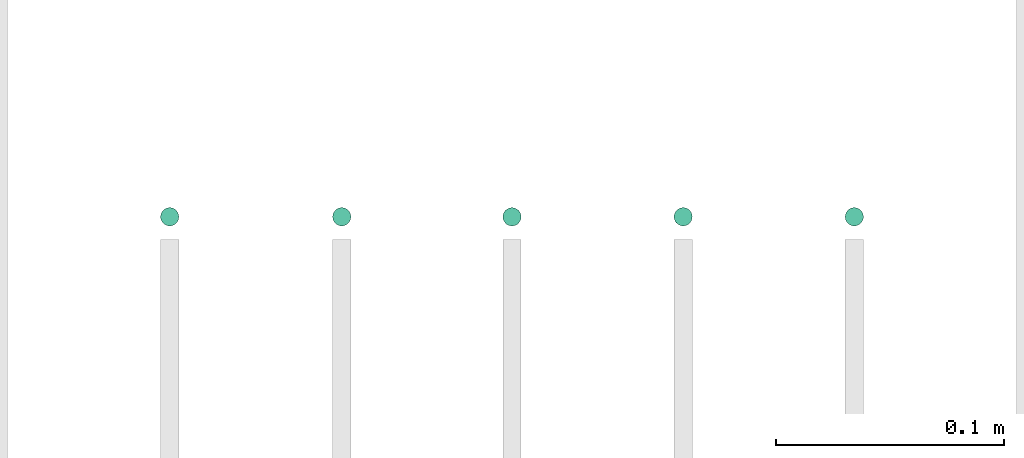
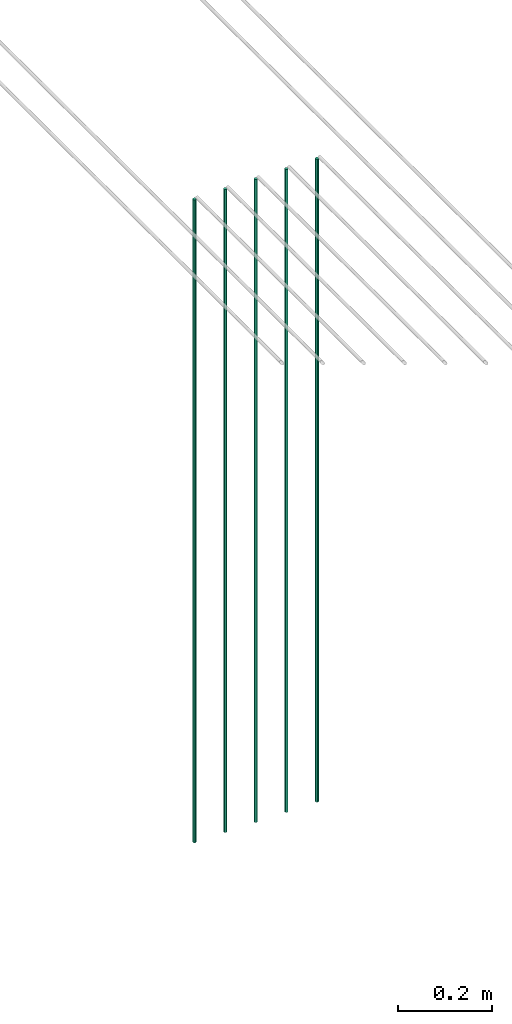
# One storey, part 12 of 89: 5 flow segments.
"""IFC2X3 building model written with IfcOpenShell, lengths in millimetres."""

from ifc_helpers import new_model, entity, si_unit, converted_unit, derived_unit, direction, frame, frame_2d, origin, origin_2d_with_axis, place, context, subcontext, project, spatial, circle, extrude, type_object, element, save


model = new_model("IFC2X3")

# Units and contexts
model_context = context("Model", 3, precision=0.01, world=origin(), true_north=direction((6.12303176911189e-17, 1.0)))
body_context = subcontext(model_context, "Body", "Model", "MODEL_VIEW")
ifc_project = project(units=[si_unit("LENGTHUNIT", "METRE", prefix="MILLI"), si_unit("AREAUNIT", "SQUARE_METRE"), si_unit("VOLUMEUNIT", "CUBIC_METRE"), converted_unit("PLANEANGLEUNIT", "DEGREE", entity("IfcRatioMeasure", 0.0174532925199433), si_unit("PLANEANGLEUNIT", "RADIAN"), dimensions=[0, 0, 0, 0, 0, 0, 0]), si_unit("MASSUNIT", "GRAM", prefix="KILO"), derived_unit("MASSDENSITYUNIT", [(si_unit("MASSUNIT", "GRAM", prefix="KILO"), 1), (si_unit("LENGTHUNIT", "METRE"), -3)]), derived_unit("MOMENTOFINERTIAUNIT", [(si_unit("LENGTHUNIT", "METRE"), 4)]), si_unit("TIMEUNIT", "SECOND"), si_unit("FREQUENCYUNIT", "HERTZ"), si_unit("THERMODYNAMICTEMPERATUREUNIT", "DEGREE_CELSIUS"), derived_unit("THERMALTRANSMITTANCEUNIT", [(si_unit("MASSUNIT", "GRAM", prefix="KILO"), 1), (si_unit("THERMODYNAMICTEMPERATUREUNIT", "KELVIN"), -1), (si_unit("TIMEUNIT", "SECOND"), -3)]), derived_unit("VOLUMETRICFLOWRATEUNIT", [(si_unit("LENGTHUNIT", "METRE"), 3), (si_unit("TIMEUNIT", "SECOND"), -1)]), derived_unit("MASSFLOWRATEUNIT", [(si_unit("MASSUNIT", "GRAM", prefix="KILO"), 1), (si_unit("TIMEUNIT", "SECOND"), -1)]), derived_unit("ROTATIONALFREQUENCYUNIT", [(si_unit("TIMEUNIT", "SECOND"), -1)]), si_unit("ELECTRICCURRENTUNIT", "AMPERE"), si_unit("ELECTRICVOLTAGEUNIT", "VOLT"), si_unit("POWERUNIT", "WATT"), si_unit("FORCEUNIT", "NEWTON", prefix="KILO"), si_unit("ILLUMINANCEUNIT", "LUX"), si_unit("LUMINOUSFLUXUNIT", "LUMEN"), si_unit("LUMINOUSINTENSITYUNIT", "CANDELA"), derived_unit("USERDEFINED", [(si_unit("MASSUNIT", "GRAM", prefix="KILO"), -1), (si_unit("LENGTHUNIT", "METRE"), -2), (si_unit("TIMEUNIT", "SECOND"), 3), (si_unit("LUMINOUSFLUXUNIT", "LUMEN"), 1)]), derived_unit("LINEARVELOCITYUNIT", [(si_unit("LENGTHUNIT", "METRE"), 1), (si_unit("TIMEUNIT", "SECOND"), -1)]), si_unit("PRESSUREUNIT", "PASCAL"), derived_unit("USERDEFINED", [(si_unit("LENGTHUNIT", "METRE"), -2), (si_unit("MASSUNIT", "GRAM", prefix="KILO"), 1), (si_unit("TIMEUNIT", "SECOND"), -2)]), derived_unit("LINEARFORCEUNIT", [(si_unit("MASSUNIT", "GRAM", prefix="KILO"), 1), (si_unit("LENGTHUNIT", "METRE"), 1), (si_unit("TIMEUNIT", "SECOND"), -2), (si_unit("LENGTHUNIT", "METRE"), -1)]), derived_unit("PLANARFORCEUNIT", [(si_unit("MASSUNIT", "GRAM", prefix="KILO"), 1), (si_unit("LENGTHUNIT", "METRE"), 1), (si_unit("TIMEUNIT", "SECOND"), -2), (si_unit("LENGTHUNIT", "METRE"), -2)])], contexts=[model_context])

# Site, building, storey
site_placement = place(None, frame((0.0, -0.00077364408347762, 0.0)))
site = spatial("IfcSite", under=ifc_project, at=site_placement, CompositionType="ELEMENT")
building_placement = place(site_placement, origin())
building = spatial("IfcBuilding", under=site, at=building_placement, CompositionType="ELEMENT")
storey_placement = place(building_placement, frame((0.0, 0.0, 24000.0)))
storey = spatial("IfcBuildingStorey", under=building, at=storey_placement, CompositionType="ELEMENT", Elevation=24000.0)

# Flow segments
pipe_segment_type = type_object("IfcPipeSegmentType", PredefinedType="NOTDEFINED")
flow_segment_1_placement = place(storey_placement, frame((53985.5981151137, 5364.40906560603, 1400.0)))
element("IfcFlowSegment", 1, at=flow_segment_1_placement, inside=storey, type_object=pipe_segment_type, context=body_context, shape_type="SweptSolid", body=[
    extrude(circle(Radius=4.0, at=origin_2d_with_axis()), frame((5.59527223591499, 5.59527223591607, 0.0)), (0.0, 0.0, 1.0), 1664.99999999999),
])
for number, where in (
    (2, (54061.0054086232, 5364.40906560602, 1400.0)),
    (3, (54135.5981151137, 5364.40906560602, 1400.0)),
    (4, (54210.5981151137, 5364.40906560602, 1400.0)),
):
    element("IfcFlowSegment", number, at=place(storey_placement, frame(where)), inside=storey, type_object=pipe_segment_type, context=body_context, shape_type="SweptSolid", body=[
        extrude(circle(Radius=4.0, at=frame_2d((0.0, -1.08286712929839e-12), x_axis=(1.0, 0.0))), frame((5.59527223591499, 5.59527223591716, 0.0)), (0.0, 0.0, 1.0), 1664.99999999999),
    ])
flow_segment_2_placement = place(storey_placement, frame((54285.5981151137, 5364.40906560602, 1400.0)))
element("IfcFlowSegment", 5, at=flow_segment_2_placement, inside=storey, type_object=pipe_segment_type, context=body_context, shape_type="SweptSolid", body=[
    extrude(circle(Radius=4.0, at=origin_2d_with_axis()), frame((5.59527223591499, 5.59527223591607, 0.0)), (0.0, 0.0, 1.0), 1665.0),
])

save(model, "model.ifc")
